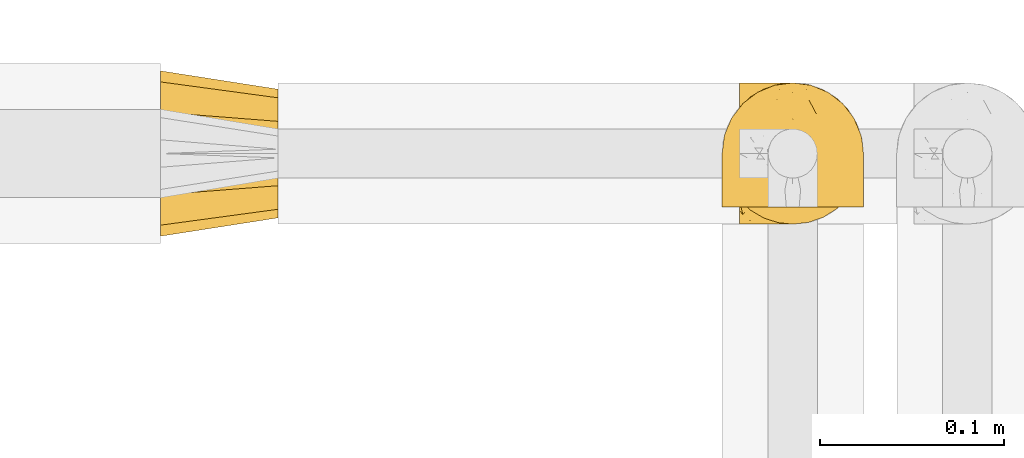
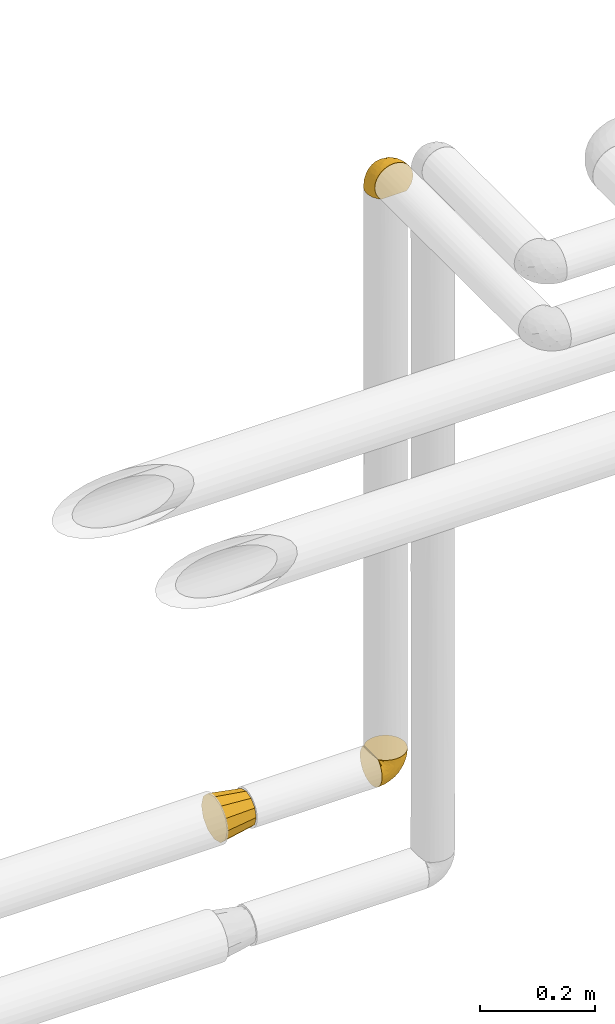
# One storey, part 369 of 827: 3 coverings.
"""IFC2X3 building model written with IfcOpenShell, lengths in millimetres."""

from ifc_helpers import new_model, entity, si_unit, converted_unit, derived_unit, direction, frame, origin, place, context, subcontext, project, spatial, faceted_brep, element, save


model = new_model("IFC2X3")

# Units and contexts
model_context = context("Model", 3, precision=0.01, world=origin(), true_north=direction((6.12303176911189e-17, 1.0)))
body_context = subcontext(model_context, "Body", "Model", "MODEL_VIEW")
ifc_project = project(units=[si_unit("LENGTHUNIT", "METRE", prefix="MILLI"), si_unit("AREAUNIT", "SQUARE_METRE"), si_unit("VOLUMEUNIT", "CUBIC_METRE"), converted_unit("PLANEANGLEUNIT", "DEGREE", entity("IfcRatioMeasure", 0.0174532925199433), si_unit("PLANEANGLEUNIT", "RADIAN"), dimensions=[0, 0, 0, 0, 0, 0, 0]), si_unit("MASSUNIT", "GRAM", prefix="KILO"), derived_unit("MASSDENSITYUNIT", [(si_unit("MASSUNIT", "GRAM", prefix="KILO"), 1), (si_unit("LENGTHUNIT", "METRE"), -3)]), derived_unit("MOMENTOFINERTIAUNIT", [(si_unit("LENGTHUNIT", "METRE"), 4)]), si_unit("TIMEUNIT", "SECOND"), si_unit("FREQUENCYUNIT", "HERTZ"), si_unit("THERMODYNAMICTEMPERATUREUNIT", "DEGREE_CELSIUS"), derived_unit("THERMALTRANSMITTANCEUNIT", [(si_unit("MASSUNIT", "GRAM", prefix="KILO"), 1), (si_unit("THERMODYNAMICTEMPERATUREUNIT", "KELVIN"), -1), (si_unit("TIMEUNIT", "SECOND"), -3)]), derived_unit("VOLUMETRICFLOWRATEUNIT", [(si_unit("LENGTHUNIT", "METRE"), 3), (si_unit("TIMEUNIT", "SECOND"), -1)]), derived_unit("MASSFLOWRATEUNIT", [(si_unit("MASSUNIT", "GRAM", prefix="KILO"), 1), (si_unit("TIMEUNIT", "SECOND"), -1)]), derived_unit("ROTATIONALFREQUENCYUNIT", [(si_unit("TIMEUNIT", "SECOND"), -1)]), si_unit("ELECTRICCURRENTUNIT", "AMPERE"), si_unit("ELECTRICVOLTAGEUNIT", "VOLT"), si_unit("POWERUNIT", "WATT"), si_unit("FORCEUNIT", "NEWTON", prefix="KILO"), si_unit("ILLUMINANCEUNIT", "LUX"), si_unit("LUMINOUSFLUXUNIT", "LUMEN"), si_unit("LUMINOUSINTENSITYUNIT", "CANDELA"), derived_unit("USERDEFINED", [(si_unit("MASSUNIT", "GRAM", prefix="KILO"), -1), (si_unit("LENGTHUNIT", "METRE"), -2), (si_unit("TIMEUNIT", "SECOND"), 3), (si_unit("LUMINOUSFLUXUNIT", "LUMEN"), 1)]), derived_unit("LINEARVELOCITYUNIT", [(si_unit("LENGTHUNIT", "METRE"), 1), (si_unit("TIMEUNIT", "SECOND"), -1)]), si_unit("PRESSUREUNIT", "PASCAL"), derived_unit("USERDEFINED", [(si_unit("LENGTHUNIT", "METRE"), -2), (si_unit("MASSUNIT", "GRAM", prefix="KILO"), 1), (si_unit("TIMEUNIT", "SECOND"), -2)]), derived_unit("LINEARFORCEUNIT", [(si_unit("MASSUNIT", "GRAM", prefix="KILO"), 1), (si_unit("LENGTHUNIT", "METRE"), 1), (si_unit("TIMEUNIT", "SECOND"), -2), (si_unit("LENGTHUNIT", "METRE"), -1)]), derived_unit("PLANARFORCEUNIT", [(si_unit("MASSUNIT", "GRAM", prefix="KILO"), 1), (si_unit("LENGTHUNIT", "METRE"), 1), (si_unit("TIMEUNIT", "SECOND"), -2), (si_unit("LENGTHUNIT", "METRE"), -2)])], contexts=[model_context])

# Site, building, storey
site_placement = place(None, origin())
site = spatial("IfcSite", under=ifc_project, at=site_placement, CompositionType="ELEMENT")
building_placement = place(site_placement, origin())
building = spatial("IfcBuilding", under=site, at=building_placement, CompositionType="ELEMENT")
storey_placement = place(building_placement, frame((0.0, 0.0, 28200.0)))
storey = spatial("IfcBuildingStorey", under=building, at=storey_placement, Name="08", CompositionType="ELEMENT", Elevation=28200.0)

# Coverings
covering_1_placement = place(storey_placement, frame((36224.33, 19454.56, 1909.95)))
element("IfcCovering", 1, at=covering_1_placement, inside=storey, Name=":ADSK_", ObjectType=":ADSK_", PredefinedType="INSULATION", context=body_context, shape_type="Brep", body=[
    faceted_brep([(47.38, 5.41, 69.15), (54.67, 9.99, 69.15), (60.76, 16.08, 69.15), (65.34, 23.37, 69.15), (68.18, 31.49, 69.15), (69.15, 40.05, 69.15), (68.18, 48.61, 69.15), (65.33, 56.73, 69.15), (60.75, 64.02, 69.15), (54.66, 70.11, 69.15), (47.37, 74.69, 69.15), (39.25, 77.53, 69.15), (30.7, 78.5, 69.15), (22.59, 77.63, 69.15), (14.86, 75.08, 69.15), (7.84, 70.97, 69.15), (1.85, 65.47, 69.15), (1.85, 63.27, 69.15), (1.85, 61.53, 69.15), (1.85, 59.57, 69.15), (1.85, 57.6, 69.15), (1.85, 55.63, 69.15), (1.85, 53.67, 69.15), (1.85, 51.7, 69.15), (1.85, 49.73, 69.15), (1.85, 47.54, 69.15), (1.85, 45.34, 69.15), (1.85, 43.15, 69.15), (1.85, 40.96, 69.15), (1.85, 38.76, 69.15), (1.85, 36.57, 69.15), (1.85, 34.37, 69.15), (1.85, 32.18, 69.15), (1.85, 29.98, 69.15), (1.85, 27.79, 69.15), (1.85, 25.6, 69.15), (1.85, 23.4, 69.15), (1.85, 21.21, 69.15), (1.85, 19.01, 69.15), (1.85, 16.82, 69.15), (1.85, 14.62, 69.15), (7.85, 9.12, 69.15), (14.88, 5.0, 69.15), (22.61, 2.46, 69.15), (30.7, 1.6, 69.15), (39.26, 2.56, 69.15), (1.6, 65.47, 68.89), (1.6, 70.97, 62.89), (1.6, 75.09, 55.87), (1.6, 77.63, 48.14), (1.6, 78.5, 40.05), (1.6, 77.19, 30.09), (1.6, 73.34, 20.82), (1.6, 67.23, 12.86), (1.6, 59.27, 6.75), (1.6, 50.0, 2.91), (1.6, 40.05, 1.6), (1.6, 30.09, 2.91), (1.6, 20.82, 6.75), (1.6, 12.86, 12.86), (1.6, 6.75, 20.82), (1.6, 2.91, 30.09), (1.6, 1.6, 40.05), (1.6, 2.46, 48.14), (1.6, 5.0, 55.87), (1.6, 9.12, 62.89), (1.6, 14.62, 68.89), (1.6, 16.82, 68.89), (1.6, 17.8, 68.89), (1.6, 19.39, 68.89), (1.6, 20.98, 68.89), (1.6, 22.57, 68.89), (1.6, 24.16, 68.89), (1.6, 25.75, 68.89), (1.6, 27.33, 68.89), (1.6, 28.92, 68.89), (1.6, 30.51, 68.89), (1.6, 32.1, 68.89), (1.6, 33.69, 68.89), (1.6, 35.28, 68.89), (1.6, 36.87, 68.89), (1.6, 38.46, 68.89), (1.6, 40.05, 68.89), (1.6, 41.63, 68.89), (1.6, 43.22, 68.89), (1.6, 44.81, 68.89), (1.6, 46.4, 68.89), (1.6, 47.99, 68.89), (1.6, 49.58, 68.89), (1.6, 51.17, 68.89), (1.6, 52.76, 68.89), (1.6, 54.72, 68.89), (1.6, 56.69, 68.89), (1.6, 58.88, 68.89), (1.6, 61.08, 68.89), (1.6, 63.27, 68.89), (1.78, 37.77, 68.97), (1.77, 36.07, 68.96), (1.78, 32.96, 68.97), (1.77, 31.36, 68.97), (1.79, 56.52, 68.98), (1.78, 54.96, 68.97), (1.76, 18.75, 68.96), (1.77, 58.07, 68.96), (1.77, 50.37, 68.96), (1.76, 23.36, 68.96), (1.77, 24.95, 68.96), (1.77, 42.43, 68.96), (1.8, 15.97, 69.0), (1.76, 51.96, 68.96), (1.77, 53.47, 68.96), (1.78, 48.63, 68.97), (1.77, 63.93, 68.96), (1.77, 40.93, 68.96), (1.76, 29.72, 68.96), (1.77, 62.4, 68.97), (1.78, 60.92, 68.97), (1.77, 17.31, 68.97), (1.77, 21.74, 68.96), (1.77, 34.56, 68.96), (1.78, 20.18, 68.97), (1.77, 14.62, 68.97), (1.8, 14.62, 69.02), (1.82, 14.62, 69.08), (1.77, 65.47, 68.97), (1.72, 65.47, 68.94), (1.66, 65.47, 68.92), (1.76, 59.5, 68.96), (1.77, 47.1, 68.96), (1.76, 45.61, 68.95), (1.77, 28.18, 68.96), (1.66, 14.62, 68.92), (1.72, 14.62, 68.94), (1.78, 26.61, 68.98), (1.82, 65.47, 69.08), (1.8, 65.47, 69.02), (1.77, 39.32, 68.96), (1.78, 44.12, 68.97), (3.72, 72.26, 61.33), (7.41, 76.57, 53.1), (6.13, 71.77, 63.33), (21.47, 78.5, 49.27), (19.34, 77.9, 55.53), (26.8, 78.5, 54.6), (8.87, 78.5, 41.99), (9.2, 75.52, 57.07), (12.79, 76.13, 57.95), (14.62, 77.81, 51.56), (7.34, 78.5, 41.58), (5.33, 72.4, 61.7), (17.64, 76.56, 63.33), (7.7, 71.77, 65.0), (9.41, 72.25, 67.02), (28.75, 78.5, 61.87), (16.15, 78.5, 43.94), (14.14, 75.75, 61.21), (29.16, 78.5, 63.4), (57.02, 50.46, 33.11), (64.92, 52.75, 52.82), (64.0, 40.05, 43.3), (11.92, 77.7, 33.73), (19.16, 77.66, 36.52), (28.65, 71.02, 24.87), (24.62, 63.45, 14.17), (15.19, 70.55, 18.43), (18.36, 75.57, 28.67), (9.2, 75.57, 26.0), (46.98, 72.61, 49.25), (50.24, 72.61, 59.72), (56.1, 67.24, 55.1), (28.97, 77.74, 44.72), (54.46, 57.43, 34.15), (21.34, 47.19, 5.25), (18.4, 54.76, 6.75), (66.44, 40.05, 55.54), (12.07, 63.45, 10.47), (45.49, 60.1, 25.49), (50.57, 63.72, 35.53), (36.04, 76.83, 48.22), (42.07, 76.34, 58.71), (62.12, 60.51, 57.42), (37.37, 72.59, 34.84), (29.39, 76.05, 36.87), (53.59, 66.15, 45.01), (58.06, 60.51, 44.4), (49.27, 51.88, 23.96), (29.63, 55.34, 11.2), (33.21, 48.67, 10.56), (40.1, 53.89, 16.81), (44.08, 46.73, 17.38), (49.36, 40.05, 21.38), (56.68, 40.05, 32.34), (15.2, 40.05, 4.3), (35.57, 63.95, 20.65), (41.7, 67.24, 29.66), (46.4, 69.62, 39.6), (41.41, 73.6, 42.55), (27.45, 40.05, 6.74), (38.4, 40.05, 14.06), (12.99, 4.52, 26.84), (21.33, 32.72, 5.28), (42.89, 27.18, 18.52), (57.04, 29.63, 33.13), (56.11, 12.86, 55.1), (62.13, 19.59, 57.43), (21.89, 9.54, 20.72), (16.62, 16.64, 11.46), (32.9, 17.48, 17.69), (46.99, 7.49, 49.26), (50.25, 7.49, 59.73), (42.08, 3.75, 58.71), (49.91, 20.75, 29.72), (15.6, 2.33, 35.35), (16.15, 1.6, 43.94), (8.87, 1.6, 41.99), (29.16, 1.6, 63.4), (13.16, 26.94, 4.93), (10.83, 9.54, 17.46), (33.8, 31.21, 10.94), (25.02, 25.33, 8.92), (64.92, 27.35, 52.83), (32.83, 8.17, 29.34), (20.56, 4.3, 30.26), (58.07, 19.59, 44.4), (21.46, 2.23, 39.06), (28.1, 2.45, 43.06), (26.8, 1.6, 54.6), (21.47, 1.6, 49.27), (51.29, 12.86, 42.69), (36.04, 3.27, 48.2), (28.75, 1.6, 61.87), (8.45, 2.29, 33.44), (41.73, 12.86, 29.67), (39.27, 6.89, 38.5), (33.56, 12.43, 23.35), (27.29, 4.1, 34.97), (7.41, 3.53, 53.1), (3.51, 6.88, 59.68), (4.68, 8.16, 62.19), (5.52, 9.02, 64.11), (8.75, 5.0, 57.97), (12.79, 3.96, 57.95), (17.65, 3.52, 63.33), (13.9, 2.4, 51.77), (9.42, 7.83, 67.02), (7.68, 8.32, 64.98), (19.33, 2.19, 55.53), (14.13, 4.34, 61.22)], [[[0, 1, 2, 3, 4, 5, 6, 7, 8, 9, 10, 11, 12, 13, 14, 15, 16, 17, 18, 19, 20, 21, 22, 23, 24, 25, 26, 27, 28, 29, 30, 31, 32, 33, 34, 35, 36, 37, 38, 39, 40, 41, 42, 43, 44, 45]], [[46, 47, 48, 49, 50, 51, 52, 53, 54, 55, 56, 57, 58, 59, 60, 61, 62, 63, 64, 65, 66, 67, 68, 69, 70, 71, 72, 73, 74, 75, 76, 77, 78, 79, 80, 81, 82, 83, 84, 85, 86, 87, 88, 89, 90, 91, 92, 93, 94, 95]], [[96, 97, 30]], [[98, 77, 99]], [[100, 101, 21]], [[69, 68, 102]], [[20, 19, 103]], [[24, 23, 104]], [[20, 103, 100]], [[72, 105, 106]], [[84, 83, 107]], [[89, 88, 104]], [[108, 67, 66]], [[109, 110, 90]], [[111, 25, 24]], [[112, 17, 16]], [[82, 113, 83]], [[109, 23, 22]], [[114, 76, 75]], [[105, 36, 106]], [[104, 111, 24]], [[18, 115, 116]], [[97, 96, 80]], [[67, 108, 117]], [[105, 71, 118]], [[31, 97, 119]], [[102, 120, 69]], [[108, 121, 122, 123, 40]], [[112, 95, 115]], [[17, 115, 18]], [[94, 116, 115]], [[117, 68, 67]], [[38, 117, 39]], [[112, 124, 125, 126, 46]], [[17, 112, 115]], [[70, 120, 118]], [[39, 117, 108]], [[120, 38, 37]], [[120, 37, 118]], [[120, 70, 69]], [[116, 94, 127]], [[128, 86, 129]], [[117, 38, 102]], [[74, 130, 75]], [[99, 33, 32]], [[115, 95, 94]], [[39, 108, 40]], [[108, 66, 131, 132, 121]], [[105, 72, 71]], [[118, 37, 36]], [[71, 70, 118]], [[35, 106, 36]], [[36, 105, 118]], [[35, 133, 106]], [[74, 73, 133]], [[106, 133, 73]], [[99, 114, 33]], [[133, 35, 34]], [[73, 72, 106]], [[95, 112, 46]], [[112, 16, 134, 135, 124]], [[130, 114, 75]], [[99, 76, 114]], [[114, 130, 33]], [[34, 33, 130]], [[78, 77, 98]], [[98, 119, 78]], [[130, 133, 34]], [[133, 130, 74]], [[79, 97, 80]], [[98, 99, 32]], [[98, 32, 31]], [[77, 76, 99]], [[97, 79, 119]], [[136, 96, 29]], [[30, 97, 31]], [[136, 29, 28]], [[81, 80, 96]], [[29, 96, 30]], [[31, 119, 98]], [[119, 79, 78]], [[96, 136, 81]], [[82, 81, 136]], [[113, 107, 83]], [[84, 107, 137]], [[107, 27, 137]], [[113, 28, 107]], [[27, 107, 28]], [[85, 84, 137]], [[137, 27, 26]], [[113, 136, 28]], [[136, 113, 82]], [[109, 89, 104]], [[86, 85, 129]], [[89, 109, 90]], [[111, 87, 128]], [[26, 129, 137]], [[88, 111, 104]], [[25, 111, 128]], [[22, 110, 109]], [[23, 109, 104]], [[110, 91, 90]], [[100, 92, 101]], [[110, 22, 101]], [[91, 110, 101]], [[116, 19, 18]], [[111, 88, 87]], [[127, 103, 19]], [[25, 128, 26]], [[86, 128, 87]], [[128, 129, 26]], [[137, 129, 85]], [[120, 102, 38]], [[117, 102, 68]], [[91, 101, 92]], [[21, 101, 22]], [[93, 92, 103]], [[100, 21, 20]], [[100, 103, 92]], [[127, 93, 103]], [[93, 127, 94]], [[116, 127, 19]], [[126, 138, 47]], [[48, 138, 139]], [[140, 125, 124]], [[141, 142, 143]], [[144, 49, 139]], [[145, 140, 146]], [[48, 139, 49]], [[139, 145, 147]], [[49, 144, 148, 50]], [[126, 125, 149]], [[14, 13, 150]], [[151, 146, 140]], [[149, 140, 145]], [[152, 151, 135]], [[152, 14, 150]], [[16, 15, 134]], [[13, 153, 150]], [[124, 151, 140]], [[141, 147, 142]], [[14, 152, 15]], [[15, 152, 134]], [[47, 46, 126]], [[139, 154, 144]], [[138, 48, 47]], [[125, 140, 149]], [[135, 134, 152]], [[146, 155, 142]], [[145, 146, 147]], [[149, 139, 138]], [[147, 141, 154]], [[147, 146, 142]], [[139, 147, 154]], [[139, 149, 145]], [[149, 138, 126]], [[155, 146, 151]], [[150, 143, 142]], [[152, 155, 151]], [[150, 142, 155]], [[13, 12, 156, 153]], [[153, 143, 150]], [[152, 150, 155]], [[151, 124, 135]], [[157, 158, 159]], [[160, 154, 161]], [[162, 163, 164]], [[165, 166, 160]], [[167, 168, 169]], [[141, 170, 161]], [[156, 12, 11]], [[158, 157, 171]], [[172, 55, 173]], [[158, 6, 174]], [[175, 54, 53]], [[52, 166, 164]], [[52, 164, 53]], [[54, 175, 173]], [[166, 52, 51]], [[176, 177, 171]], [[178, 143, 179]], [[156, 11, 179]], [[8, 7, 180]], [[169, 9, 8]], [[179, 143, 153, 156]], [[179, 11, 10]], [[168, 179, 10]], [[181, 162, 182]], [[179, 167, 178]], [[183, 184, 177]], [[183, 169, 184]], [[176, 171, 185]], [[172, 186, 187]], [[158, 7, 6]], [[159, 158, 174]], [[184, 180, 158]], [[54, 173, 55]], [[180, 169, 8]], [[188, 189, 187]], [[9, 168, 10]], [[186, 188, 187]], [[190, 157, 159, 191]], [[55, 172, 192]], [[176, 193, 194]], [[161, 170, 182]], [[162, 164, 165]], [[175, 164, 163]], [[51, 50, 148]], [[167, 195, 196]], [[178, 182, 170]], [[6, 5, 174]], [[158, 180, 7]], [[169, 180, 184]], [[169, 168, 9]], [[179, 168, 167]], [[182, 162, 165]], [[162, 194, 193]], [[161, 165, 160]], [[195, 181, 196]], [[192, 172, 197]], [[192, 56, 55]], [[189, 190, 198]], [[198, 197, 187]], [[172, 187, 197]], [[185, 189, 188]], [[198, 187, 189]], [[186, 172, 173]], [[173, 163, 186]], [[193, 186, 163]], [[176, 185, 188]], [[185, 157, 190]], [[188, 186, 193]], [[177, 176, 194]], [[188, 193, 176]], [[162, 193, 163]], [[195, 177, 194]], [[171, 177, 184]], [[181, 195, 194]], [[183, 167, 169]], [[162, 181, 194]], [[196, 182, 178]], [[158, 171, 184]], [[171, 157, 185]], [[177, 195, 183]], [[167, 183, 195]], [[182, 196, 181]], [[178, 170, 143]], [[178, 167, 196]], [[164, 175, 53]], [[173, 175, 163]], [[160, 51, 148]], [[164, 166, 165]], [[51, 160, 166]], [[160, 148, 144, 154]], [[141, 161, 154]], [[182, 165, 161]], [[190, 189, 185]], [[143, 170, 141]], [[60, 199, 61]], [[197, 200, 192]], [[201, 190, 202]], [[200, 57, 192]], [[203, 204, 2]], [[205, 206, 207]], [[208, 209, 210]], [[211, 207, 201]], [[212, 213, 214]], [[45, 215, 210]], [[216, 206, 58]], [[45, 44, 215]], [[59, 217, 60]], [[60, 217, 199]], [[0, 45, 210]], [[218, 201, 219]], [[202, 159, 220]], [[205, 221, 222]], [[223, 204, 203]], [[1, 203, 2]], [[57, 200, 216]], [[220, 3, 204]], [[220, 174, 4]], [[1, 0, 209]], [[212, 224, 213]], [[225, 226, 227]], [[228, 223, 203]], [[208, 210, 229]], [[210, 226, 229]], [[3, 220, 4]], [[58, 206, 59]], [[209, 203, 1]], [[202, 220, 223]], [[228, 203, 208]], [[202, 211, 201]], [[3, 2, 204]], [[202, 190, 191, 159]], [[210, 215, 230, 226]], [[199, 212, 231]], [[232, 233, 221]], [[233, 208, 229]], [[207, 206, 219]], [[217, 206, 205]], [[227, 224, 225]], [[233, 232, 228]], [[201, 207, 219]], [[234, 232, 221]], [[218, 219, 200]], [[202, 223, 211]], [[174, 220, 159]], [[174, 5, 4]], [[61, 231, 62]], [[220, 204, 223]], [[210, 209, 0]], [[203, 209, 208]], [[225, 233, 229]], [[224, 227, 213]], [[221, 233, 235]], [[57, 56, 192]], [[198, 218, 197]], [[200, 219, 216]], [[201, 198, 190]], [[197, 218, 200]], [[198, 201, 218]], [[206, 216, 219]], [[58, 57, 216]], [[231, 212, 214]], [[222, 212, 199]], [[228, 211, 223]], [[207, 211, 232]], [[62, 231, 214]], [[199, 231, 61]], [[233, 228, 208]], [[211, 228, 232]], [[222, 221, 235]], [[234, 205, 207]], [[206, 217, 59]], [[199, 217, 205]], [[205, 222, 199]], [[224, 222, 235]], [[222, 224, 212]], [[224, 235, 225]], [[233, 225, 235]], [[226, 225, 229]], [[205, 234, 221]], [[207, 232, 234]], [[63, 214, 236]], [[214, 213, 236]], [[214, 63, 62]], [[237, 236, 238]], [[238, 132, 131]], [[236, 237, 64]], [[239, 240, 241]], [[63, 236, 64]], [[131, 66, 65]], [[237, 131, 65]], [[242, 230, 43]], [[237, 65, 64]], [[239, 121, 132]], [[42, 242, 43]], [[241, 240, 243]], [[41, 123, 244]], [[43, 230, 215, 44]], [[244, 122, 245]], [[227, 246, 243]], [[241, 247, 245]], [[121, 239, 245]], [[41, 40, 123]], [[132, 238, 239]], [[244, 42, 41]], [[131, 237, 238]], [[240, 239, 238]], [[245, 239, 241]], [[247, 241, 246]], [[247, 244, 245]], [[238, 236, 240]], [[243, 236, 213]], [[236, 243, 240]], [[227, 226, 246]], [[243, 213, 227]], [[242, 246, 226]], [[243, 246, 241]], [[246, 242, 247]], [[244, 247, 242]], [[242, 226, 230]], [[42, 244, 242]], [[122, 244, 123]], [[122, 121, 245]]]),
])
covering_2_placement = place(storey_placement, frame((36214.98, 19463.91, 3169.3)))
element("IfcCovering", 2, at=covering_2_placement, inside=storey, Name=":ADSK_", ObjectType=":ADSK_", PredefinedType="INSULATION", context=body_context, shape_type="Brep", body=[
    faceted_brep([(74.68, 1.6, 47.38), (70.1, 1.6, 54.67), (64.01, 1.6, 60.76), (56.72, 1.6, 65.34), (48.6, 1.6, 68.18), (40.05, 1.6, 69.15), (31.49, 1.6, 68.18), (23.36, 1.6, 65.33), (16.07, 1.6, 60.75), (9.98, 1.6, 54.66), (5.4, 1.6, 47.37), (2.56, 1.6, 39.25), (1.6, 1.6, 30.7), (2.46, 1.6, 22.59), (5.01, 1.6, 14.86), (9.13, 1.6, 7.84), (14.62, 1.6, 1.85), (16.82, 1.6, 1.85), (18.56, 1.6, 1.85), (20.52, 1.6, 1.85), (22.49, 1.6, 1.85), (24.46, 1.6, 1.85), (26.42, 1.6, 1.85), (28.39, 1.6, 1.85), (30.36, 1.6, 1.85), (32.55, 1.6, 1.85), (34.75, 1.6, 1.85), (36.94, 1.6, 1.85), (39.13, 1.6, 1.85), (41.33, 1.6, 1.85), (43.52, 1.6, 1.85), (45.72, 1.6, 1.85), (47.91, 1.6, 1.85), (50.11, 1.6, 1.85), (52.3, 1.6, 1.85), (54.49, 1.6, 1.85), (56.69, 1.6, 1.85), (58.88, 1.6, 1.85), (61.08, 1.6, 1.85), (63.27, 1.6, 1.85), (65.47, 1.6, 1.85), (70.97, 1.6, 7.85), (75.09, 1.6, 14.88), (77.64, 1.6, 22.61), (78.5, 1.6, 30.7), (77.53, 1.6, 39.26), (14.62, 1.85, 1.6), (9.12, 7.85, 1.6), (5.0, 14.87, 1.6), (2.46, 22.6, 1.6), (1.6, 30.7, 1.6), (2.91, 40.65, 1.6), (6.75, 49.92, 1.6), (12.86, 57.88, 1.6), (20.82, 63.99, 1.6), (30.09, 67.84, 1.6), (40.05, 69.15, 1.6), (50.0, 67.84, 1.6), (59.27, 63.99, 1.6), (67.23, 57.88, 1.6), (73.34, 49.92, 1.6), (77.19, 40.65, 1.6), (78.5, 30.7, 1.6), (77.63, 22.6, 1.6), (75.09, 14.87, 1.6), (70.97, 7.85, 1.6), (65.47, 1.85, 1.6), (63.27, 1.85, 1.6), (62.29, 1.85, 1.6), (60.7, 1.85, 1.6), (59.11, 1.85, 1.6), (57.52, 1.85, 1.6), (55.93, 1.85, 1.6), (54.34, 1.85, 1.6), (52.76, 1.85, 1.6), (51.17, 1.85, 1.6), (49.58, 1.85, 1.6), (47.99, 1.85, 1.6), (46.4, 1.85, 1.6), (44.81, 1.85, 1.6), (43.22, 1.85, 1.6), (41.63, 1.85, 1.6), (40.05, 1.85, 1.6), (38.46, 1.85, 1.6), (36.87, 1.85, 1.6), (35.28, 1.85, 1.6), (33.69, 1.85, 1.6), (32.1, 1.85, 1.6), (30.51, 1.85, 1.6), (28.92, 1.85, 1.6), (27.33, 1.85, 1.6), (25.37, 1.85, 1.6), (23.4, 1.85, 1.6), (21.21, 1.85, 1.6), (19.01, 1.85, 1.6), (16.82, 1.85, 1.6), (42.32, 1.77, 1.78), (44.02, 1.78, 1.77), (47.13, 1.77, 1.78), (48.74, 1.77, 1.77), (23.57, 1.76, 1.79), (25.13, 1.77, 1.78), (61.34, 1.79, 1.76), (22.02, 1.78, 1.77), (29.72, 1.78, 1.77), (56.73, 1.78, 1.76), (55.14, 1.78, 1.77), (37.66, 1.78, 1.77), (64.12, 1.74, 1.8), (28.13, 1.78, 1.76), (26.62, 1.78, 1.77), (31.46, 1.77, 1.78), (16.16, 1.78, 1.77), (39.16, 1.78, 1.77), (50.37, 1.78, 1.76), (17.69, 1.77, 1.77), (19.17, 1.77, 1.78), (62.78, 1.77, 1.77), (58.35, 1.78, 1.77), (45.53, 1.78, 1.77), (59.91, 1.77, 1.78), (65.47, 1.77, 1.77), (65.47, 1.72, 1.8), (65.47, 1.66, 1.82), (14.62, 1.77, 1.77), (14.62, 1.8, 1.72), (14.62, 1.82, 1.66), (20.59, 1.79, 1.76), (32.99, 1.78, 1.77), (34.48, 1.79, 1.76), (51.91, 1.78, 1.77), (65.47, 1.82, 1.66), (65.47, 1.8, 1.72), (53.48, 1.76, 1.78), (14.62, 1.66, 1.82), (14.62, 1.72, 1.8), (40.77, 1.78, 1.77), (35.97, 1.77, 1.78), (7.84, 9.41, 3.72), (3.53, 17.65, 7.41), (8.32, 7.41, 6.13), (2.19, 15.21, 19.34), (3.53, 7.41, 17.64), (1.6, 16.15, 26.8), (1.6, 28.75, 8.87), (4.57, 13.67, 9.2), (3.96, 12.79, 12.79), (2.28, 19.18, 14.62), (1.6, 29.16, 7.34), (7.69, 9.04, 5.33), (8.32, 5.74, 7.7), (7.84, 3.72, 9.41), (1.6, 8.87, 28.75), (1.6, 21.47, 21.47), (1.6, 26.8, 16.15), (4.34, 9.53, 14.14), (1.6, 7.34, 29.16), (29.63, 37.63, 57.02), (27.34, 17.92, 64.92), (40.05, 27.45, 64.0), (2.39, 37.01, 11.92), (2.43, 34.22, 19.16), (9.07, 45.87, 28.65), (16.64, 56.57, 24.62), (9.54, 52.31, 15.19), (4.52, 42.07, 18.36), (4.52, 44.74, 9.2), (7.49, 21.49, 46.98), (7.49, 11.02, 50.24), (12.85, 15.64, 56.1), (2.35, 26.02, 28.97), (22.66, 36.59, 54.46), (32.9, 65.49, 21.34), (25.33, 63.99, 18.4), (40.05, 15.2, 66.44), (16.64, 60.27, 12.07), (19.99, 45.25, 45.49), (16.37, 35.21, 50.57), (3.26, 22.52, 36.04), (3.75, 12.03, 42.07), (19.58, 13.32, 62.12), (7.5, 35.9, 37.37), (4.04, 33.87, 29.39), (13.94, 25.73, 53.59), (19.58, 26.34, 58.06), (28.21, 46.78, 49.27), (24.75, 59.54, 29.63), (31.42, 60.18, 33.21), (26.2, 53.93, 40.1), (33.36, 53.36, 44.08), (40.05, 49.36, 49.36), (40.05, 38.4, 56.68), (40.05, 66.44, 15.2), (16.14, 50.09, 35.57), (12.85, 41.08, 41.7), (10.47, 31.14, 46.4), (6.49, 28.19, 41.41), (40.05, 64.0, 27.45), (40.05, 56.68, 38.4), (75.57, 43.9, 12.99), (47.37, 65.46, 21.33), (52.91, 52.22, 42.89), (50.46, 37.61, 57.04), (67.23, 15.64, 56.11), (60.5, 13.31, 62.13), (70.55, 50.02, 21.89), (63.45, 59.28, 16.62), (62.61, 53.05, 32.9), (72.6, 21.48, 46.99), (72.6, 11.01, 50.25), (76.34, 12.03, 42.08), (59.34, 41.02, 49.91), (77.76, 35.39, 15.6), (78.5, 26.8, 16.15), (78.5, 28.75, 8.87), (78.5, 7.34, 29.16), (53.16, 65.81, 13.16), (70.55, 53.28, 10.83), (48.88, 59.8, 33.8), (54.76, 61.82, 25.02), (52.74, 17.91, 64.92), (71.93, 41.4, 32.83), (75.79, 40.48, 20.56), (60.5, 26.34, 58.07), (77.86, 31.68, 21.46), (77.64, 27.68, 28.1), (78.5, 16.15, 26.8), (78.5, 21.47, 21.47), (67.23, 28.05, 51.29), (76.82, 22.54, 36.04), (78.5, 8.87, 28.75), (77.8, 37.3, 8.45), (67.23, 41.07, 41.73), (73.2, 32.24, 39.27), (67.66, 47.4, 33.56), (75.99, 35.77, 27.29), (76.57, 17.65, 7.41), (73.21, 11.06, 3.51), (71.93, 8.55, 4.68), (71.07, 6.63, 5.52), (75.09, 12.77, 8.75), (76.13, 12.79, 12.79), (76.57, 7.41, 17.65), (77.69, 18.97, 13.9), (72.26, 3.72, 9.42), (71.77, 5.76, 7.68), (77.9, 15.21, 19.33), (75.75, 9.52, 14.13)], [[[0, 1, 2, 3, 4, 5, 6, 7, 8, 9, 10, 11, 12, 13, 14, 15, 16, 17, 18, 19, 20, 21, 22, 23, 24, 25, 26, 27, 28, 29, 30, 31, 32, 33, 34, 35, 36, 37, 38, 39, 40, 41, 42, 43, 44, 45]], [[46, 47, 48, 49, 50, 51, 52, 53, 54, 55, 56, 57, 58, 59, 60, 61, 62, 63, 64, 65, 66, 67, 68, 69, 70, 71, 72, 73, 74, 75, 76, 77, 78, 79, 80, 81, 82, 83, 84, 85, 86, 87, 88, 89, 90, 91, 92, 93, 94, 95]], [[96, 97, 30]], [[98, 77, 99]], [[100, 101, 21]], [[69, 68, 102]], [[20, 19, 103]], [[24, 23, 104]], [[20, 103, 100]], [[72, 105, 106]], [[84, 83, 107]], [[89, 88, 104]], [[108, 67, 66]], [[109, 110, 90]], [[111, 25, 24]], [[112, 17, 16]], [[82, 113, 83]], [[109, 23, 22]], [[114, 76, 75]], [[105, 36, 106]], [[104, 111, 24]], [[18, 115, 116]], [[97, 96, 80]], [[67, 108, 117]], [[105, 71, 118]], [[31, 97, 119]], [[102, 120, 69]], [[108, 121, 122, 123, 40]], [[112, 95, 115]], [[17, 115, 18]], [[94, 116, 115]], [[117, 68, 67]], [[38, 117, 39]], [[112, 124, 125, 126, 46]], [[17, 112, 115]], [[70, 120, 118]], [[39, 117, 108]], [[120, 38, 37]], [[120, 37, 118]], [[120, 70, 69]], [[116, 94, 127]], [[128, 86, 129]], [[117, 38, 102]], [[74, 130, 75]], [[99, 33, 32]], [[115, 95, 94]], [[39, 108, 40]], [[108, 66, 131, 132, 121]], [[105, 72, 71]], [[118, 37, 36]], [[71, 70, 118]], [[35, 106, 36]], [[36, 105, 118]], [[35, 133, 106]], [[74, 73, 133]], [[106, 133, 73]], [[99, 114, 33]], [[133, 35, 34]], [[73, 72, 106]], [[95, 112, 46]], [[112, 16, 134, 135, 124]], [[130, 114, 75]], [[99, 76, 114]], [[114, 130, 33]], [[34, 33, 130]], [[78, 77, 98]], [[98, 119, 78]], [[130, 133, 34]], [[133, 130, 74]], [[79, 97, 80]], [[98, 99, 32]], [[98, 32, 31]], [[77, 76, 99]], [[97, 79, 119]], [[136, 96, 29]], [[30, 97, 31]], [[136, 29, 28]], [[81, 80, 96]], [[29, 96, 30]], [[31, 119, 98]], [[119, 79, 78]], [[96, 136, 81]], [[82, 81, 136]], [[113, 107, 83]], [[84, 107, 137]], [[107, 27, 137]], [[113, 28, 107]], [[27, 107, 28]], [[85, 84, 137]], [[137, 27, 26]], [[113, 136, 28]], [[136, 113, 82]], [[109, 89, 104]], [[86, 85, 129]], [[89, 109, 90]], [[111, 87, 128]], [[26, 129, 137]], [[88, 111, 104]], [[25, 111, 128]], [[22, 110, 109]], [[23, 109, 104]], [[110, 91, 90]], [[100, 92, 101]], [[110, 22, 101]], [[91, 110, 101]], [[116, 19, 18]], [[111, 88, 87]], [[127, 103, 19]], [[25, 128, 26]], [[86, 128, 87]], [[128, 129, 26]], [[137, 129, 85]], [[120, 102, 38]], [[117, 102, 68]], [[91, 101, 92]], [[21, 101, 22]], [[93, 92, 103]], [[100, 21, 20]], [[100, 103, 92]], [[127, 93, 103]], [[93, 127, 94]], [[116, 127, 19]], [[126, 138, 47]], [[48, 138, 139]], [[140, 125, 124]], [[141, 142, 143]], [[144, 49, 139]], [[145, 140, 146]], [[48, 139, 49]], [[139, 145, 147]], [[49, 144, 148, 50]], [[126, 125, 149]], [[14, 13, 142]], [[150, 146, 140]], [[149, 140, 145]], [[151, 150, 135]], [[151, 14, 142]], [[16, 15, 134]], [[13, 152, 142]], [[124, 150, 140]], [[141, 143, 153]], [[14, 151, 15]], [[15, 151, 134]], [[47, 46, 126]], [[139, 154, 144]], [[138, 48, 47]], [[125, 140, 149]], [[135, 134, 151]], [[146, 155, 141]], [[145, 146, 147]], [[149, 139, 138]], [[147, 153, 154]], [[147, 146, 141]], [[139, 147, 154]], [[139, 149, 145]], [[149, 138, 126]], [[147, 141, 153]], [[146, 150, 155]], [[151, 155, 150]], [[142, 141, 155]], [[13, 12, 156, 152]], [[152, 143, 142]], [[151, 142, 155]], [[150, 124, 135]], [[157, 158, 159]], [[160, 154, 161]], [[162, 163, 164]], [[165, 166, 160]], [[167, 168, 169]], [[153, 170, 161]], [[156, 12, 11]], [[158, 157, 171]], [[172, 55, 173]], [[158, 6, 174]], [[175, 54, 53]], [[52, 166, 164]], [[52, 164, 53]], [[54, 175, 173]], [[166, 52, 51]], [[176, 177, 171]], [[178, 143, 179]], [[156, 11, 179]], [[8, 7, 180]], [[169, 9, 8]], [[179, 143, 152, 156]], [[179, 11, 10]], [[168, 179, 10]], [[181, 162, 182]], [[179, 167, 178]], [[183, 184, 177]], [[183, 169, 184]], [[176, 171, 185]], [[172, 186, 187]], [[158, 7, 6]], [[159, 158, 174]], [[184, 180, 158]], [[54, 173, 55]], [[180, 169, 8]], [[188, 189, 187]], [[9, 168, 10]], [[186, 188, 187]], [[190, 157, 159, 191]], [[55, 172, 192]], [[176, 193, 194]], [[161, 170, 182]], [[162, 164, 165]], [[175, 164, 163]], [[51, 50, 148]], [[167, 195, 196]], [[178, 182, 170]], [[6, 5, 174]], [[158, 180, 7]], [[169, 180, 184]], [[169, 168, 9]], [[179, 168, 167]], [[182, 162, 165]], [[162, 194, 193]], [[161, 165, 160]], [[195, 181, 196]], [[192, 172, 197]], [[192, 56, 55]], [[189, 190, 198]], [[198, 197, 187]], [[172, 187, 197]], [[185, 189, 188]], [[198, 187, 189]], [[186, 172, 173]], [[173, 163, 186]], [[193, 186, 163]], [[176, 185, 188]], [[185, 157, 190]], [[188, 186, 193]], [[177, 176, 194]], [[188, 193, 176]], [[162, 193, 163]], [[195, 177, 194]], [[171, 177, 184]], [[181, 195, 194]], [[183, 167, 169]], [[162, 181, 194]], [[196, 182, 178]], [[158, 171, 184]], [[171, 157, 185]], [[177, 195, 183]], [[167, 183, 195]], [[182, 196, 181]], [[178, 170, 143]], [[178, 167, 196]], [[164, 175, 53]], [[173, 175, 163]], [[160, 51, 148]], [[164, 166, 165]], [[51, 160, 166]], [[160, 148, 144, 154]], [[153, 161, 154]], [[182, 165, 161]], [[190, 189, 185]], [[143, 170, 153]], [[60, 199, 61]], [[197, 200, 192]], [[201, 190, 202]], [[200, 57, 192]], [[203, 204, 2]], [[205, 206, 207]], [[208, 209, 210]], [[211, 207, 201]], [[212, 213, 214]], [[45, 215, 210]], [[216, 206, 58]], [[45, 44, 215]], [[59, 217, 60]], [[60, 217, 199]], [[0, 45, 210]], [[218, 201, 219]], [[202, 159, 220]], [[205, 221, 222]], [[223, 204, 203]], [[1, 203, 2]], [[57, 200, 216]], [[220, 3, 204]], [[220, 174, 4]], [[1, 0, 209]], [[212, 224, 213]], [[225, 226, 227]], [[228, 223, 203]], [[208, 210, 229]], [[210, 226, 229]], [[3, 220, 4]], [[58, 206, 59]], [[209, 203, 1]], [[202, 220, 223]], [[228, 203, 208]], [[202, 211, 201]], [[3, 2, 204]], [[202, 190, 191, 159]], [[210, 215, 230, 226]], [[199, 212, 231]], [[232, 233, 221]], [[233, 208, 229]], [[207, 206, 219]], [[217, 206, 205]], [[227, 224, 225]], [[233, 232, 228]], [[201, 207, 219]], [[234, 232, 221]], [[218, 219, 200]], [[202, 223, 211]], [[174, 220, 159]], [[174, 5, 4]], [[61, 231, 62]], [[220, 204, 223]], [[210, 209, 0]], [[203, 209, 208]], [[225, 233, 229]], [[224, 227, 213]], [[221, 233, 235]], [[57, 56, 192]], [[198, 218, 197]], [[200, 219, 216]], [[201, 198, 190]], [[197, 218, 200]], [[198, 201, 218]], [[206, 216, 219]], [[58, 57, 216]], [[231, 212, 214]], [[222, 212, 199]], [[228, 211, 223]], [[207, 211, 232]], [[62, 231, 214]], [[199, 231, 61]], [[233, 228, 208]], [[211, 228, 232]], [[222, 221, 235]], [[234, 205, 207]], [[206, 217, 59]], [[199, 217, 205]], [[205, 222, 199]], [[224, 222, 235]], [[222, 224, 212]], [[224, 235, 225]], [[233, 225, 235]], [[226, 225, 229]], [[205, 234, 221]], [[207, 232, 234]], [[63, 214, 236]], [[214, 213, 236]], [[214, 63, 62]], [[237, 236, 238]], [[238, 132, 131]], [[236, 237, 64]], [[239, 240, 241]], [[63, 236, 64]], [[131, 66, 65]], [[237, 131, 65]], [[242, 230, 43]], [[237, 65, 64]], [[239, 121, 132]], [[42, 242, 43]], [[241, 240, 243]], [[41, 123, 244]], [[43, 230, 215, 44]], [[244, 122, 245]], [[227, 246, 243]], [[245, 241, 247]], [[121, 239, 245]], [[41, 40, 123]], [[132, 238, 239]], [[244, 42, 41]], [[131, 237, 238]], [[240, 239, 238]], [[245, 239, 241]], [[247, 241, 246]], [[247, 244, 245]], [[238, 236, 240]], [[243, 236, 213]], [[236, 243, 240]], [[246, 241, 243]], [[243, 213, 227]], [[226, 242, 246]], [[227, 226, 246]], [[246, 242, 247]], [[244, 247, 242]], [[242, 226, 230]], [[42, 244, 242]], [[122, 244, 123]], [[122, 121, 245]]]),
])
covering_3_placement = place(storey_placement, frame((35911.02, 19448.01, 1903.4)))
element("IfcCovering", 3, at=covering_3_placement, inside=storey, Name=":ADSK_", ObjectType=":ADSK_", PredefinedType="INSULATION", context=body_context, shape_type="Brep", body=[
    faceted_brep([(0.0, 77.33, 77.33), (0.0, 85.57, 69.1), (0.0, 88.17, 59.38), (0.0, 91.6, 46.6), (0.0, 88.17, 33.81), (0.0, 85.57, 24.1), (0.0, 77.33, 15.86), (0.0, 69.1, 7.62), (0.0, 59.38, 5.02), (0.0, 46.6, 1.6), (0.0, 33.81, 5.02), (0.0, 24.1, 7.62), (0.0, 15.86, 15.86), (0.0, 7.62, 24.1), (0.0, 5.02, 33.81), (0.0, 1.6, 46.6), (0.0, 5.02, 59.38), (0.0, 7.62, 69.1), (0.0, 15.86, 77.33), (0.0, 24.1, 85.57), (0.0, 33.81, 88.17), (0.0, 46.6, 91.6), (0.0, 59.38, 88.17), (0.0, 69.1, 85.57), (64.0, 29.1, 76.91), (64.0, 22.69, 70.5), (64.0, 16.28, 64.1), (64.0, 13.94, 55.35), (64.0, 11.6, 46.6), (64.0, 13.94, 37.85), (64.0, 16.28, 29.1), (64.0, 22.69, 22.69), (64.0, 29.1, 16.28), (64.0, 37.85, 13.94), (64.0, 46.6, 11.6), (64.0, 55.35, 13.94), (64.0, 64.1, 16.28), (64.0, 70.5, 22.69), (64.0, 76.91, 29.1), (64.0, 79.25, 37.85), (64.0, 81.6, 46.6), (64.0, 79.25, 55.35), (64.0, 76.91, 64.1), (64.0, 70.5, 70.5), (64.0, 64.1, 76.91), (64.0, 55.35, 79.25), (64.0, 46.6, 81.6), (64.0, 37.85, 79.25)], [[[0, 1, 2, 3, 4, 5, 6, 7, 8, 9, 10, 11, 12, 13, 14, 15, 16, 17, 18, 19, 20, 21, 22, 23]], [[24, 25, 26, 27, 28, 29, 30, 31, 32, 33, 34, 35, 36, 37, 38, 39, 40, 41, 42, 43, 44, 45, 46, 47]], [[38, 5, 4, 3, 40, 39]], [[6, 5, 38, 37, 36, 7]], [[35, 34, 9, 8, 7, 36]], [[32, 11, 10, 9, 34, 33]], [[12, 11, 32, 31, 30, 13]], [[29, 28, 15, 14, 13, 30]], [[26, 17, 16, 15, 28, 27]], [[18, 17, 26, 25, 24, 19]], [[47, 46, 21, 20, 19, 24]], [[44, 23, 22, 21, 46, 45]], [[0, 23, 44, 43, 42, 1]], [[41, 40, 3, 2, 1, 42]]]),
])

save(model, "model.ifc")
